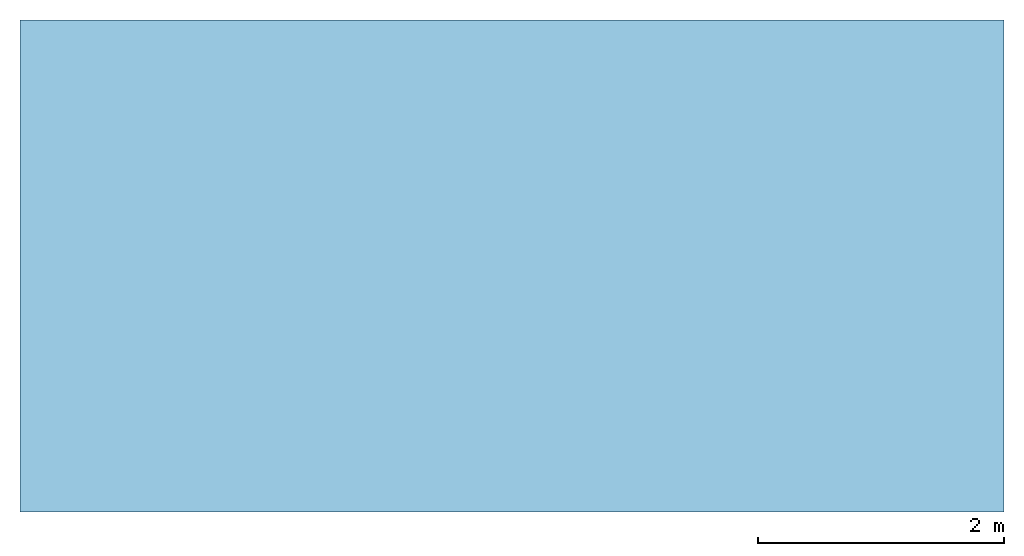
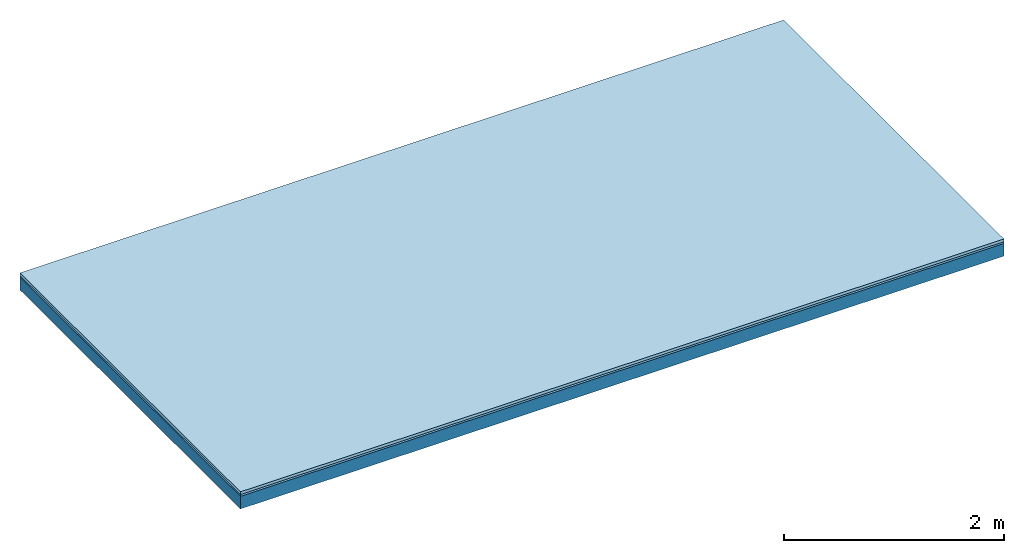
# One storey: 2 plates, 1 member, 1 element without a shape of its own.
"""IFC4 building model written with IfcOpenShell, lengths in metres."""

from ifc_helpers import new_model, si_unit, derived_unit, direction, frame, frame_2d, origin, origin_with_axes, place, context, project, spatial, rectangle, extrude, material, layer, layer_set, type_object, element, aggregate, save


model = new_model("IFC4")

# Units and contexts
plan_context = context("Plan", 3, precision=1e-05, world=origin(), true_north=direction((0.0, 1.0)))
model_context = context("Model", 3, precision=1e-05, world=origin(), true_north=direction((0.0, 1.0)))
ifc_project = project(units=[si_unit("LENGTHUNIT", "METRE"), derived_unit("SOUNDPRESSUREUNIT", [(si_unit("PRESSUREUNIT", "PASCAL", prefix="MICRO"), 0)]), si_unit("ENERGYUNIT", "JOULE", prefix="MEGA"), si_unit("MASSUNIT", "GRAM", prefix="KILO"), derived_unit("THERMALTRANSMITTANCEUNIT", [(si_unit("POWERUNIT", "WATT"), 1), (si_unit("AREAUNIT", "SQUARE_METRE"), -1), (si_unit("THERMODYNAMICTEMPERATUREUNIT", "KELVIN"), -1)]), derived_unit("AREADENSITYUNIT", [(si_unit("MASSUNIT", "GRAM", prefix="KILO"), 1), (si_unit("AREAUNIT", "SQUARE_METRE"), -1)]), derived_unit("USERDEFINED", [(si_unit("ENERGYUNIT", "JOULE", prefix="MEGA"), 1), (si_unit("AREAUNIT", "SQUARE_METRE"), -1)])], contexts=[plan_context, model_context])

# Site, building, storey
site = spatial("IfcSite", under=ifc_project)
building_placement = place(None, origin())
building = spatial("IfcBuilding", under=site, at=building_placement)
storey_placement = place(building_placement, origin())
storey = spatial("IfcBuildingStorey", under=building, at=storey_placement)

# Slab, member, plates
ifc_material_1 = material(Name="Phone Star TRI", Category="03.013")
ifc_layer_1 = layer(ifc_material_1, 0.03, Name="On-material")
ifc_material_2 = material(Name="Floor 140", Category="10.009")
ifc_layer_2 = layer(ifc_material_2, 0.02, Name="Impact sound insulation")
ifc_material_3 = material(Name="no composite action")
ifc_layer_3 = layer(ifc_material_3, 0.0, Name="Bond")
ifc_layer_4 = layer(None, 0.14, Name="Supporting structure")
ifc_layer_set = layer_set([ifc_layer_1, ifc_layer_2, ifc_layer_3, ifc_layer_4])
slab_type = type_object("IfcSlabType", Name="A2526", PredefinedType="NOTDEFINED", material=ifc_layer_set)
slab_placement = place(None, frame((0.0, 0.0, 0.0), z_axis=(0.0, 0.0, -1.0), x_axis=(1.0, 0.0, 0.0)))
slab = element("IfcSlab", 1, at=slab_placement, inside=storey, type_object=slab_type, material=ifc_layer_set, Name="Slab #1")
ifc_material_4 = material()
member_placement = place(slab_placement, origin())
member = element("IfcMember", 2, at=member_placement, material=ifc_material_4, Name="Supporting structure", context=plan_context, shape_type="SweptSolid", body=[
    extrude(rectangle(XDim=1.0, YDim=0.14, at=frame_2d((0.5, 0.07), x_axis=(1.0, 0.0))), frame((0.0, 4.0, 0.05), z_axis=(0.0, -1.0, 0.0), x_axis=(1.0, 0.0, 0.0)), (0.0, 0.0, 1.0), 4.0),
    extrude(rectangle(XDim=1.0, YDim=0.14, at=frame_2d((0.5, 0.07), x_axis=(1.0, 0.0))), frame((1.0, 4.0, 0.05), z_axis=(0.0, -1.0, 0.0), x_axis=(1.0, 0.0, 0.0)), (0.0, 0.0, 1.0), 4.0),
    extrude(rectangle(XDim=1.0, YDim=0.14, at=frame_2d((0.5, 0.07), x_axis=(1.0, 0.0))), frame((2.0, 4.0, 0.05), z_axis=(0.0, -1.0, 0.0), x_axis=(1.0, 0.0, 0.0)), (0.0, 0.0, 1.0), 4.0),
    extrude(rectangle(XDim=1.0, YDim=0.14, at=frame_2d((0.5, 0.07), x_axis=(1.0, 0.0))), frame((3.0, 4.0, 0.05), z_axis=(0.0, -1.0, 0.0), x_axis=(1.0, 0.0, 0.0)), (0.0, 0.0, 1.0), 4.0),
    extrude(rectangle(XDim=1.0, YDim=0.14, at=frame_2d((0.5, 0.07), x_axis=(1.0, 0.0))), frame((4.0, 4.0, 0.05), z_axis=(0.0, -1.0, 0.0), x_axis=(1.0, 0.0, 0.0)), (0.0, 0.0, 1.0), 4.0),
    extrude(rectangle(XDim=1.0, YDim=0.14, at=frame_2d((0.5, 0.07), x_axis=(1.0, 0.0))), frame((5.0, 4.0, 0.05), z_axis=(0.0, -1.0, 0.0), x_axis=(1.0, 0.0, 0.0)), (0.0, 0.0, 1.0), 4.0),
    extrude(rectangle(XDim=1.0, YDim=0.14, at=frame_2d((0.5, 0.07), x_axis=(1.0, 0.0))), frame((6.0, 4.0, 0.05), z_axis=(0.0, -1.0, 0.0), x_axis=(1.0, 0.0, 0.0)), (0.0, 0.0, 1.0), 4.0),
    extrude(rectangle(XDim=1.0, YDim=0.14, at=frame_2d((0.5, 0.07), x_axis=(1.0, 0.0))), frame((7.0, 4.0, 0.05), z_axis=(0.0, -1.0, 0.0), x_axis=(1.0, 0.0, 0.0)), (0.0, 0.0, 1.0), 4.0),
])
plate_1_placement = place(slab_placement, origin())
plate_1 = element("IfcPlate", 3, at=plate_1_placement, material=ifc_material_1, Name="On-material", context=plan_context, shape_type="SweptSolid", body=[
    extrude(rectangle(XDim=8.0, YDim=4.0, at=frame_2d((4.0, 2.0), x_axis=(1.0, 0.0))), origin_with_axes(), (0.0, 0.0, 1.0), 0.03),
])
plate_2_placement = place(slab_placement, origin())
plate_2 = element("IfcPlate", 4, at=plate_2_placement, material=ifc_material_2, Name="Impact sound insulation", context=plan_context, shape_type="SweptSolid", body=[
    extrude(rectangle(XDim=8.0, YDim=4.0, at=frame_2d((4.0, 2.0), x_axis=(1.0, 0.0))), frame((0.0, 0.0, 0.03), z_axis=(0.0, 0.0, 1.0), x_axis=(1.0, 0.0, 0.0)), (0.0, 0.0, 1.0), 0.02),
])
aggregate(slab, [plate_1, plate_2, member])

save(model, "model.ifc")
